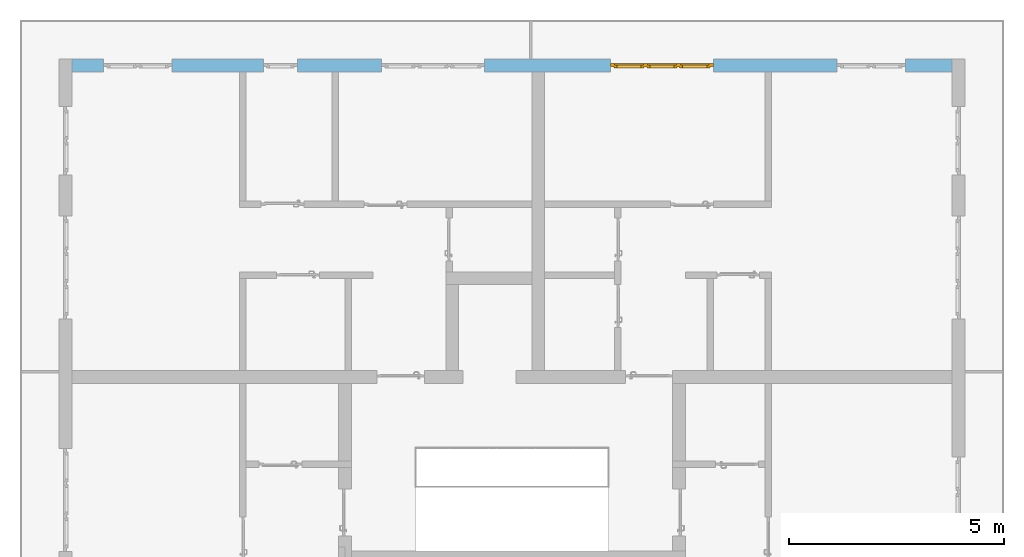
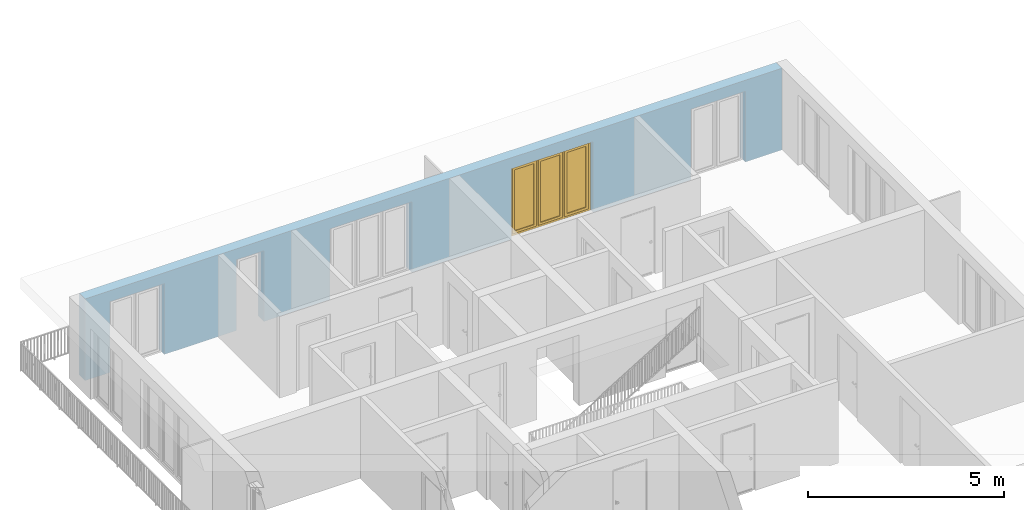
# One storey, part 28 of 54: 1 window, 5 openings, plus 1 element that does not belong to this part.
"""IFC4 building model written with IfcOpenShell, lengths in metres."""

import ifcopenshell
import ifcopenshell.guid

model = None  # the IFC model being written
_history = None  # IfcOwnerHistory: only IFC2X3 demands one
_inside = {}  # id of a spatial element -> (the spatial element, [elements in it])
_under = {}  # id of a project, library or spatial element -> (it, [spatial elements below it])
_declared = {}  # id of a project -> (the project, [libraries it declares])
_typed = {}  # id of a type object -> (the type object, [elements of that type])
_made_of = {}  # id of a material, layer set ... -> (it, [elements and type objects made of it])


def new_model(schema):
    """Start an empty IFC model of exactly this schema.

    Asked for "IFC4X3", IfcOpenShell would pick the latest addendum, in which some entities
    have other attributes; the version numbers below select the first issue.
    IFC2X3 requires an IfcOwnerHistory on every rooted entity: one is made here for all.
    """
    global model, _history
    if schema == "IFC4X3":
        model = ifcopenshell.file(schema_version=(4, 3, 0, 0))
    else:
        model = ifcopenshell.file(schema=schema)
    _inside.clear()
    _under.clear()
    _declared.clear()
    _typed.clear()
    _made_of.clear()
    _history = None
    if model.schema == "IFC2X3":
        org = make("IfcOrganization", Name="unknown")
        user = make(
            "IfcPersonAndOrganization",
            ThePerson=make("IfcPerson", FamilyName="unknown"),
            TheOrganization=org,
        )
        app = make(
            "IfcApplication",
            ApplicationDeveloper=org,
            Version="unknown",
            ApplicationFullName="unknown",
            ApplicationIdentifier="unknown",
        )
        _history = make(
            "IfcOwnerHistory",
            OwningUser=user,
            OwningApplication=app,
            ChangeAction="ADDED",
            CreationDate=0,
        )
    return model


def make(cls, **values):
    """One entity of the class cls with the attributes given. An attribute that is None is left unset."""
    return model.create_entity(
        cls, **{name: value for name, value in values.items() if value is not None}
    )


def entity(cls, *values):
    """Any entity or typed value of the class cls, its attributes in the order of the schema. None: left unset."""
    e = model.create_entity(cls)
    for i, value in enumerate(values):
        if value is not None:
            e[i] = value
    return e


def rooted(cls, **values):
    """An entity with a GlobalId (a new one), such as an element, a storey or a relation."""
    return make(cls, GlobalId=ifcopenshell.guid.new(), OwnerHistory=_history, **values)


def si_unit(unit_type, name, prefix=None):
    """IfcSIUnit, for example si_unit("LENGTHUNIT", "METRE", prefix="MILLI")."""
    return make("IfcSIUnit", UnitType=unit_type, Prefix=prefix, Name=name)


def converted_unit(unit_type, name, factor, base, dimensions=None, offset=None):
    """IfcConversionBasedUnit, such as the inch: factor (a typed value) times the base unit."""
    return make(
        "IfcConversionBasedUnit"
        if offset is None
        else "IfcConversionBasedUnitWithOffset",
        ConversionOffset=offset,
        Dimensions=None
        if dimensions is None
        else entity("IfcDimensionalExponents", *dimensions),
        UnitType=unit_type,
        Name=name,
        ConversionFactor=make(
            "IfcMeasureWithUnit", ValueComponent=factor, UnitComponent=base
        ),
    )


def derived_unit(unit_type, elements):
    """IfcDerivedUnit: a product of units, each with its exponent."""
    return make(
        "IfcDerivedUnit",
        Elements=[
            make("IfcDerivedUnitElement", Unit=unit, Exponent=power)
            for unit, power in elements
        ],
        UnitType=unit_type,
    )


def assignment(units):
    """IfcUnitAssignment: the units of a project."""
    return None if units is None else make("IfcUnitAssignment", Units=units)


def point(xyz):
    """IfcCartesianPoint."""
    return None if xyz is None else make("IfcCartesianPoint", Coordinates=xyz)


def direction(xyz):
    """IfcDirection."""
    return None if xyz is None else make("IfcDirection", DirectionRatios=xyz)


def frame(location, z_axis=None, x_axis=None):
    """IfcAxis2Placement3D, a coordinate frame: its origin and axes. An axis left out is left unset."""
    return make(
        "IfcAxis2Placement3D",
        Location=point(location),
        Axis=direction(z_axis),
        RefDirection=direction(x_axis),
    )


def origin_with_axes():
    """The frame at (0, 0, 0) with the z axis (0, 0, 1) and the x axis (1, 0, 0) written out."""
    return frame((0.0, 0.0, 0.0), z_axis=(0.0, 0.0, 1.0), x_axis=(1.0, 0.0, 0.0))


def place(relative_to, where):
    """IfcLocalPlacement: puts the frame where relative to a parent placement (None: the world)."""
    return make(
        "IfcLocalPlacement", PlacementRelTo=relative_to, RelativePlacement=where
    )


def context(
    kind, dimensions, precision=None, world=None, true_north=None, identifier=None
):
    """IfcGeometricRepresentationContext, for example the 3D "Model" context."""
    return make(
        "IfcGeometricRepresentationContext",
        ContextIdentifier=identifier,
        ContextType=kind,
        CoordinateSpaceDimension=dimensions,
        Precision=precision,
        WorldCoordinateSystem=world,
        TrueNorth=true_north,
    )


def subcontext(parent, identifier, kind, view, scale=None):
    """IfcGeometricRepresentationSubContext, for example "Body" below "Model"."""
    return make(
        "IfcGeometricRepresentationSubContext",
        ContextIdentifier=identifier,
        ContextType=kind,
        ParentContext=parent,
        TargetScale=scale,
        TargetView=view,
    )


def project(units=None, contexts=None):
    """IfcProject with its units and contexts."""
    return rooted(
        "IfcProject",
        Name="project",
        RepresentationContexts=contexts,
        UnitsInContext=assignment(units),
    )


def spatial(cls, under=None, at=None, **own):
    """A site, building, storey or space (cls), placed at a placement, below another one or the project."""
    s = rooted(cls, ObjectPlacement=at, **own)
    if under is not None:
        _under.setdefault(under.id(), (under, []))[1].append(s)
    return s


def point_list(points):
    """IfcCartesianPointList2D or 3D."""
    cls = (
        "IfcCartesianPointList2D" if len(points[0]) == 2 else "IfcCartesianPointList3D"
    )
    return make(cls, CoordList=points)


def polygons(points, faces, closed=None, point_numbers=None):
    """IfcPolygonalFaceSet: a face is its outer loop, then its inner loops; points numbered from 1."""
    made = []
    for loops in faces:
        if len(loops) == 1:
            made.append(make("IfcIndexedPolygonalFace", CoordIndex=loops[0]))
        else:
            made.append(
                make(
                    "IfcIndexedPolygonalFaceWithVoids",
                    CoordIndex=loops[0],
                    InnerCoordIndices=loops[1:],
                )
            )
    return make(
        "IfcPolygonalFaceSet",
        Coordinates=point_list(points),
        Closed=closed,
        Faces=made,
        PnIndex=point_numbers,
    )


def shape(context_of_items, identifier, shape_type, items):
    """IfcShapeRepresentation: the items that make up one representation, for example the "Body"."""
    return make(
        "IfcShapeRepresentation",
        ContextOfItems=context_of_items,
        RepresentationIdentifier=identifier,
        RepresentationType=shape_type,
        Items=items,
    )


def source(mapping_origin, context_of_items, identifier, shape_type, items):
    """IfcRepresentationMap: a shape defined once, which mapped items show again and again."""
    return make(
        "IfcRepresentationMap",
        MappingOrigin=mapping_origin,
        MappedRepresentation=shape(context_of_items, identifier, shape_type, items),
    )


def transform(
    local_origin,
    x_axis=None,
    y_axis=None,
    z_axis=None,
    scale=None,
    scale2=None,
    scale3=None,
    uniform=True,
):
    """IfcCartesianTransformationOperator3D, or its non-uniform kind. x_axis, y_axis, z_axis: its Axis1, 2, 3."""
    if uniform:
        return make(
            "IfcCartesianTransformationOperator3D",
            Axis1=direction(x_axis),
            Axis2=direction(y_axis),
            LocalOrigin=point(local_origin),
            Scale=scale,
            Axis3=direction(z_axis),
        )
    return make(
        "IfcCartesianTransformationOperator3DnonUniform",
        Axis1=direction(x_axis),
        Axis2=direction(y_axis),
        LocalOrigin=point(local_origin),
        Scale=scale,
        Axis3=direction(z_axis),
        Scale2=scale2,
        Scale3=scale3,
    )


def mapped(mapping_source, mapping_target):
    """IfcMappedItem: shows the shape of a source again, moved by a transform."""
    return make(
        "IfcMappedItem", MappingSource=mapping_source, MappingTarget=mapping_target
    )


def material(Name=None, Category=None):
    """IfcMaterial."""
    return make("IfcMaterial", Name=Name, Category=Category)


def made_of(thing, what):
    """Note that an element or type object is made of a material, layer set ...; save() writes the relation."""
    if what is not None:
        _made_of.setdefault(what.id(), (what, []))[1].append(thing)
    return thing


def type_object(cls, material=None, **own):
    """A type object (cls), such as IfcWallType, which elements share."""
    return made_of(rooted(cls, **own), material)


def element(
    cls,
    number,
    at=None,
    inside=None,
    cuts=None,
    type_object=None,
    material=None,
    context=None,
    identifier="Body",
    shape_type=None,
    held_by="IfcProductDefinitionShape",
    body=None,
    shapes=None,
    **own,
):
    """One element of the class cls, such as IfcWall. Its Tag is "e" and its number.

    at: its placement. inside: the storey or other place that contains it. cuts: it is an
    opening in that element (IfcRelVoidsElement). A single representation is given by context,
    identifier, shape_type and body (its items); several are given by shapes. held_by: the class
    of the entity that holds the representations. save() writes the other relations.
    """
    e = rooted(cls, Tag="e%d" % number, ObjectPlacement=at, **own)
    if body is not None:
        shapes = [shape(context, identifier, shape_type, body)]
    if shapes is not None:
        e.Representation = make(held_by, Representations=shapes)
    if inside is not None:
        _inside.setdefault(inside.id(), (inside, []))[1].append(e)
    if cuts is not None:
        rooted(
            "IfcRelVoidsElement", RelatingBuildingElement=cuts, RelatedOpeningElement=e
        )
    if type_object is not None:
        _typed.setdefault(type_object.id(), (type_object, []))[1].append(e)
    return made_of(e, material)


def fill(opening, filler):
    """IfcRelFillsElement: the door or window that sits in an opening."""
    return rooted(
        "IfcRelFillsElement",
        RelatingOpeningElement=opening,
        RelatedBuildingElement=filler,
    )


def aggregate(whole, parts):
    """IfcRelAggregates: a whole, such as a stair, and the parts it consists of."""
    return rooted("IfcRelAggregates", RelatingObject=whole, RelatedObjects=parts)


def save(model, path):
    """Write the relations noted so far, then the file.

    IfcRelAggregates (storeys below a building ...), IfcRelContainedInSpatialStructure (elements
    in a storey), IfcRelDefinesByType, IfcRelAssociatesMaterial and IfcRelDeclares: one each for
    every whole, place, type object, material and project.
    """
    for whole, parts in _under.values():
        aggregate(whole, parts)
    for where, things in _inside.values():
        rooted(
            "IfcRelContainedInSpatialStructure",
            RelatedElements=things,
            RelatingStructure=where,
        )
    for kind, things in _typed.values():
        rooted("IfcRelDefinesByType", RelatedObjects=things, RelatingType=kind)
    for what, things in _made_of.values():
        rooted("IfcRelAssociatesMaterial", RelatedObjects=things, RelatingMaterial=what)
    for by, libraries in _declared.values():
        rooted("IfcRelDeclares", RelatingContext=by, RelatedDefinitions=libraries)
    model.write(path)


model = new_model("IFC4")

# Units and contexts
model_context = context("Model", 3, precision=1e-05, world=origin_with_axes(), true_north=direction((0.0, 1.0)))
body_context = subcontext(model_context, "Body", "Model", "MODEL_VIEW")
ifc_project = project(units=[si_unit("LENGTHUNIT", "METRE"), si_unit("AREAUNIT", "SQUARE_METRE"), si_unit("VOLUMEUNIT", "CUBIC_METRE"), converted_unit("PLANEANGLEUNIT", "DEGREE", entity("IfcPlaneAngleMeasure", 0.0174532925199), si_unit("PLANEANGLEUNIT", "RADIAN"), dimensions=[0, 0, 0, 0, 0, 0, 0]), converted_unit("TIMEUNIT", "Year", entity("IfcTimeMeasure", 31556926.0), si_unit("TIMEUNIT", "SECOND"), dimensions=[0, 0, 1, 0, 0, 0, 0]), si_unit("MASSUNIT", "GRAM", prefix="KILO"), si_unit("THERMODYNAMICTEMPERATUREUNIT", "DEGREE_CELSIUS"), si_unit("LUMINOUSINTENSITYUNIT", "LUMEN"), si_unit("ENERGYUNIT", "JOULE", prefix="MEGA"), derived_unit("THERMALCONDUCTANCEUNIT", [(si_unit("POWERUNIT", "WATT"), 1), (si_unit("LENGTHUNIT", "METRE"), -1), (si_unit("THERMODYNAMICTEMPERATUREUNIT", "KELVIN"), -1)]), derived_unit("SPECIFICHEATCAPACITYUNIT", [(si_unit("ENERGYUNIT", "JOULE"), 1), (si_unit("MASSUNIT", "GRAM", prefix="KILO"), -1), (si_unit("THERMODYNAMICTEMPERATUREUNIT", "KELVIN"), -1)]), derived_unit("MASSDENSITYUNIT", [(si_unit("MASSUNIT", "GRAM", prefix="KILO"), 1), (si_unit("VOLUMEUNIT", "CUBIC_METRE"), -1)])], contexts=[model_context])

# Site, building, storey
site_placement = place(None, origin_with_axes())
site = spatial("IfcSite", under=ifc_project, at=site_placement, CompositionType="ELEMENT")
building_placement = place(site_placement, origin_with_axes())
building = spatial("IfcBuilding", under=site, at=building_placement, CompositionType="ELEMENT")
storey_placement = place(building_placement, frame((0.0, 0.0, 6.29), z_axis=(0.0, 0.0, 1.0), x_axis=(1.0, 0.0, 0.0)))
storey = spatial("IfcBuildingStorey", under=building, at=storey_placement, Name="2. Geschoss", CompositionType="ELEMENT", Elevation=6.29)

# Wall, openings, window
ifc_material = material()
wall_type = type_object("IfcWallType", Name="300", PredefinedType="NOTDEFINED")
wall_placement = place(storey_placement, frame((-11.7421993804, 8.92118776896, 0.0), z_axis=(0.0, 0.0, 1.0), x_axis=(1.0, 0.0, 0.0)))
wall = element("IfcWall", 1, at=wall_placement, inside=storey, type_object=wall_type, material=ifc_material, Name="Wand-001", PredefinedType="NOTDEFINED", context=body_context, shape_type="Tessellation", body=[
    polygons([(15.23, -0.1, 0.0), (15.23, -0.3, 0.0), (15.23, -0.3, 2.2), (15.23, 0.0, 2.2), (15.23, 0.0, 0.0), (18.102139809, 0.0, 0.0), (18.102139809, -0.3, 0.0), (18.102139809, -0.3, 2.2), (19.702139809, -0.3, 2.2), (19.702139809, -0.3, 0.0), (20.78, -0.3, 0.0), (20.78, -0.3, 2.54), (0.3, -0.3, 2.54), (0.3, -0.3, 0.0), (1.0288518641, -0.3, 0.0), (1.0288518641, -0.3, 2.2), (2.6288518641, -0.3, 2.2), (2.6288518641, -0.3, 0.0), (4.75, -0.3, 0.0), (4.75, -0.3, 2.2), (5.55, -0.3, 2.2), (5.55, -0.3, 0.0), (7.50089858046, -0.3, 0.0), (7.50089858046, -0.3, 2.2), (9.90089858046, -0.3, 2.2), (9.90089858046, -0.3, 0.0), (12.83, -0.3, 0.0), (12.83, -0.3, 2.2), (12.83, 0.0, 2.2), (12.83, 0.0, 0.0), (9.90089858046, 0.0, 0.0), (9.90089858046, 0.0, 2.2), (7.50089858046, 0.0, 2.2), (7.50089858046, 0.0, 0.0), (5.55, 0.0, 0.0), (5.55, 0.0, 2.2), (4.75, 0.0, 2.2), (4.75, 0.0, 0.0), (2.6288518641, 0.0, 0.0), (2.6288518641, 0.0, 2.2), (1.0288518641, 0.0, 2.2), (1.0288518641, 0.0, 0.0), (0.3, 0.0, 0.0), (0.3, 0.0, 2.54), (20.78, 0.0, 2.54), (20.78, 0.0, 0.0), (19.702139809, 0.0, 0.0), (19.702139809, 0.0, 2.2), (18.102139809, 0.0, 2.2), (12.83, -0.1, 0.0)], [[[1, 2, 3, 4, 5]], [[2, 1, 5, 6, 7]], [[3, 2, 7, 8, 9, 10, 11, 12, 13, 14, 15, 16, 17, 18, 19, 20, 21, 22, 23, 24, 25, 26, 27, 28]], [[4, 3, 28, 29]], [[6, 5, 4, 29, 30, 31, 32, 33, 34, 35, 36, 37, 38, 39, 40, 41, 42, 43, 44, 45, 46, 47, 48, 49]], [[6, 49, 8, 7]], [[8, 49, 48, 9]], [[48, 47, 10, 9]], [[46, 11, 10, 47]], [[12, 11, 46, 45]], [[45, 44, 13, 12]], [[44, 43, 14, 13]], [[15, 14, 43, 42]], [[16, 15, 42, 41]], [[40, 17, 16, 41]], [[18, 17, 40, 39]], [[19, 18, 39, 38]], [[20, 19, 38, 37]], [[36, 21, 20, 37]], [[22, 21, 36, 35]], [[22, 35, 34, 23]], [[34, 33, 24, 23]], [[24, 33, 32, 25]], [[32, 31, 26, 25]], [[50, 27, 26, 31, 30]], [[28, 27, 50, 30, 29]]], closed=True),
])
opening_1_placement = place(wall_placement, frame((1.8288518641, 0.0, 0.0), z_axis=(0.0, 0.0, 1.0), x_axis=(1.0, 0.0, 0.0)))
element("IfcOpeningElement", 2, at=opening_1_placement, cuts=wall, Name="Fenster-001", context=body_context, identifier="Reference", shape_type="Tessellation", body=[
    polygons([(-0.8, -0.1, 0.0), (-0.8, -0.1, 2.2), (-0.8, 0.000999999999998, 2.2), (-0.8, 0.000999999999998, 0.0), (-0.8, -0.301, 0.0), (-0.8, -0.301, 2.2), (0.8, -0.1, 2.2), (0.8, 0.000999999999999, 2.2), (0.8, -0.301, 2.2), (0.8, 0.000999999999999, 0.0), (0.8, -0.1, 0.0), (0.8, -0.301, 0.0)], [[[1, 2, 3, 4]], [[2, 1, 5, 6]], [[7, 8, 3, 2, 6, 9]], [[8, 10, 4, 3]], [[1, 4, 10, 11, 12, 5]], [[6, 5, 12, 9]], [[7, 11, 10, 8]], [[11, 7, 9, 12]]], closed=True),
])
opening_2_placement = place(wall_placement, frame((8.70089858046, 0.0, 0.0), z_axis=(0.0, 0.0, 1.0), x_axis=(1.0, 0.0, 0.0)))
element("IfcOpeningElement", 3, at=opening_2_placement, cuts=wall, Name="Fenster-002", context=body_context, identifier="Reference", shape_type="Tessellation", body=[
    polygons([(-1.2, -0.1, 0.0), (-1.2, -0.1, 2.2), (-1.2, 0.000999999999999, 2.2), (-1.2, 0.000999999999999, 0.0), (-1.2, -0.301, 0.0), (-1.2, -0.301, 2.2), (1.2, -0.1, 2.2), (1.2, 0.001, 2.2), (1.2, -0.301, 2.2), (1.2, 0.001, 0.0), (1.2, -0.1, 0.0), (1.2, -0.301, 0.0)], [[[1, 2, 3, 4]], [[2, 1, 5, 6]], [[7, 8, 3, 2, 6, 9]], [[8, 10, 4, 3]], [[1, 4, 10, 11, 12, 5]], [[6, 5, 12, 9]], [[7, 11, 10, 8]], [[11, 7, 9, 12]]], closed=True),
])
opening_3_placement = place(wall_placement, frame((5.15, 0.0, 0.0), z_axis=(0.0, 0.0, 1.0), x_axis=(1.0, 0.0, 0.0)))
element("IfcOpeningElement", 4, at=opening_3_placement, cuts=wall, Name="Fenster-003", context=body_context, identifier="Reference", shape_type="Tessellation", body=[
    polygons([(-0.4, -0.1, 0.0), (-0.4, -0.1, 2.2), (-0.4, 0.001, 2.2), (-0.4, 0.001, 0.0), (-0.4, -0.301, 0.0), (-0.4, -0.301, 2.2), (0.4, -0.1, 2.2), (0.4, 0.001, 2.2), (0.4, -0.301, 2.2), (0.4, 0.001, 0.0), (0.4, -0.1, 0.0), (0.4, -0.301, 0.0)], [[[1, 2, 3, 4]], [[2, 1, 5, 6]], [[7, 8, 3, 2, 6, 9]], [[8, 10, 4, 3]], [[1, 4, 10, 11, 12, 5]], [[6, 5, 12, 9]], [[7, 11, 10, 8]], [[11, 7, 9, 12]]], closed=True),
])
opening_4_placement = place(wall_placement, frame((18.902139809, 0.0, 0.0), z_axis=(0.0, 0.0, 1.0), x_axis=(1.0, 0.0, 0.0)))
element("IfcOpeningElement", 5, at=opening_4_placement, cuts=wall, Name="Fenster-001", context=body_context, identifier="Reference", shape_type="Tessellation", body=[
    polygons([(-0.8, -0.1, 0.0), (-0.8, -0.1, 2.2), (-0.8, 0.001, 2.2), (-0.8, 0.001, 0.0), (-0.8, -0.301, 0.0), (-0.8, -0.301, 2.2), (0.8, -0.1, 2.2), (0.8, 0.001, 2.2), (0.8, -0.301, 2.2), (0.8, 0.001, 0.0), (0.8, -0.1, 0.0), (0.8, -0.301, 0.0)], [[[1, 2, 3, 4]], [[2, 1, 5, 6]], [[7, 8, 3, 2, 6, 9]], [[8, 10, 4, 3]], [[1, 4, 10, 11, 12, 5]], [[6, 5, 12, 9]], [[7, 11, 10, 8]], [[11, 7, 9, 12]]], closed=True),
])
opening_5_placement = place(wall_placement, frame((14.03, 0.0, 0.0), z_axis=(0.0, 0.0, 1.0), x_axis=(1.0, 0.0, 0.0)))
opening_5 = element("IfcOpeningElement", 6, at=opening_5_placement, cuts=wall, Name="Fenster-002", context=body_context, identifier="Reference", shape_type="Tessellation", body=[
    polygons([(-1.2, -0.1, 0.0), (-1.2, -0.1, 2.2), (-1.2, 0.001, 2.2), (-1.2, 0.001, 0.0), (-1.2, -0.301, 0.0), (-1.2, -0.301, 2.2), (1.2, -0.1, 2.2), (1.2, 0.001, 2.2), (1.2, -0.301, 2.2), (1.2, 0.001, 0.0), (1.2, -0.1, 0.0), (1.2, -0.301, 0.0)], [[[1, 2, 3, 4]], [[2, 1, 5, 6]], [[7, 8, 3, 2, 6, 9]], [[8, 10, 4, 3]], [[1, 4, 10, 11, 12, 5]], [[6, 5, 12, 9]], [[7, 11, 10, 8]], [[11, 7, 9, 12]]], closed=True),
])
window_type = type_object("IfcWindowType", Name="3-1+1+1 26", PartitioningType="TRIPLE_PANEL_VERTICAL", PredefinedType="WINDOW")
shared_shape = source(origin_with_axes(), body_context, "Body", "Tessellation", [
    polygons([(-1.2, -0.07, 0.0), (-1.2, 0.0, 0.0), (-1.1, 0.0, 0.1), (-1.1, -0.07, 0.1), (-1.2, -0.07, 2.2), (-1.2, 0.0, 2.2), (-1.1, 0.0, 2.1), (-1.1, -0.07, 2.1)], [[[1, 2, 3, 4]], [[5, 6, 2, 1]], [[2, 6, 7, 3]], [[4, 3, 7, 8]], [[1, 4, 8, 5]], [[8, 7, 6, 5]]], closed=True),
    polygons([(1.2, -0.07, 0.0), (1.2, 0.0, 0.0), (1.2, 0.0, 2.2), (1.2, -0.07, 2.2), (1.1, -0.07, 0.1), (1.1, 0.0, 0.1), (1.1, 0.0, 2.1), (1.1, -0.07, 2.1)], [[[1, 2, 3, 4]], [[5, 6, 2, 1]], [[2, 6, 7, 3]], [[4, 3, 7, 8]], [[1, 4, 8, 5]], [[8, 7, 6, 5]]], closed=True),
    polygons([(-1.2, -0.07, 0.0), (-1.2, 0.0, 0.0), (1.2, 0.0, 0.0), (1.2, -0.07, 0.0), (-1.1, -0.07, 0.1), (-1.1, 0.0, 0.1), (-0.433333333333, 0.0, 0.1), (-0.333333333333, 0.0, 0.1), (0.333333333333, 0.0, 0.1), (0.433333333333, 0.0, 0.1), (1.1, 0.0, 0.1), (1.1, -0.07, 0.1), (0.433333333333, -0.07, 0.1), (0.333333333333, -0.07, 0.1), (-0.333333333333, -0.07, 0.1), (-0.433333333333, -0.07, 0.1)], [[[1, 2, 3, 4]], [[5, 6, 2, 1]], [[2, 6, 7, 8, 9, 10, 11, 3]], [[4, 3, 11, 12]], [[1, 4, 12, 13, 14, 15, 16, 5]], [[16, 7, 6, 5]], [[15, 8, 7, 16]], [[14, 9, 8, 15]], [[13, 10, 9, 14]], [[12, 11, 10, 13]]], closed=True),
    polygons([(-1.2, -0.07, 2.2), (-1.2, 0.0, 2.2), (-1.1, 0.0, 2.1), (-1.1, -0.07, 2.1), (1.2, -0.07, 2.2), (1.2, 0.0, 2.2), (1.1, 0.0, 2.1), (0.433333333333, 0.0, 2.1), (0.333333333333, 0.0, 2.1), (-0.333333333333, 0.0, 2.1), (-0.433333333333, 0.0, 2.1), (-0.433333333333, -0.07, 2.1), (-0.333333333333, -0.07, 2.1), (0.333333333333, -0.07, 2.1), (0.433333333333, -0.07, 2.1), (1.1, -0.07, 2.1)], [[[1, 2, 3, 4]], [[5, 6, 2, 1]], [[2, 6, 7, 8, 9, 10, 11, 3]], [[4, 3, 11, 12]], [[1, 4, 12, 13, 14, 15, 16, 5]], [[16, 7, 6, 5]], [[15, 8, 7, 16]], [[14, 9, 8, 15]], [[13, 10, 9, 14]], [[12, 11, 10, 13]]], closed=True),
    polygons([(0.333333333333, -0.07, 0.1), (0.333333333333, 0.0, 0.1), (0.433333333333, 0.0, 0.1), (0.433333333333, -0.07, 0.1), (0.333333333333, -0.07, 2.1), (0.333333333333, 0.0, 2.1), (0.433333333333, 0.0, 2.1), (0.433333333333, -0.07, 2.1)], [[[1, 2, 3, 4]], [[5, 6, 2, 1]], [[2, 6, 7, 3]], [[4, 3, 7, 8]], [[1, 4, 8, 5]], [[8, 7, 6, 5]]], closed=True),
    polygons([(-0.433333333333, -0.07, 0.1), (-0.433333333333, 0.0, 0.1), (-0.333333333333, 0.0, 0.1), (-0.333333333333, -0.07, 0.1), (-0.433333333333, -0.07, 2.1), (-0.433333333333, 0.0, 2.1), (-0.333333333333, 0.0, 2.1), (-0.333333333333, -0.07, 2.1)], [[[1, 2, 3, 4]], [[5, 6, 2, 1]], [[2, 6, 7, 3]], [[4, 3, 7, 8]], [[1, 4, 8, 5]], [[8, 7, 6, 5]]], closed=True),
    polygons([(-1.12, 0.0, 0.08), (-1.12, 0.03, 0.08), (-1.05, 0.03, 0.15), (-1.05, 0.0, 0.15), (-1.12, 0.0, 2.12), (-1.12, 0.03, 2.12), (-1.05, 0.03, 2.05), (-1.05, 0.0, 2.05)], [[[1, 2, 3, 4]], [[5, 6, 2, 1]], [[2, 6, 7, 3]], [[4, 3, 7, 8]], [[1, 4, 8, 5]], [[8, 7, 6, 5]]], closed=True),
    polygons([(-0.413333333333, 0.0, 0.08), (-0.483333333333, 0.0, 0.15), (-0.483333333333, 0.03, 0.15), (-0.413333333333, 0.03, 0.08), (-0.413333333333, 0.0, 2.12), (-0.483333333333, 0.0, 2.05), (-0.483333333333, 0.03, 2.05), (-0.413333333333, 0.03, 2.12)], [[[1, 2, 3, 4]], [[1, 5, 6, 2]], [[2, 6, 7, 3]], [[4, 3, 7, 8]], [[5, 1, 4, 8]], [[6, 5, 8, 7]]], closed=True),
    polygons([(-1.12, 0.0, 0.08), (-1.12, 0.03, 0.08), (-0.413333333333, 0.03, 0.08), (-0.413333333333, 0.0, 0.08), (-1.05, 0.0, 0.15), (-1.05, 0.03, 0.15), (-0.483333333333, 0.03, 0.15), (-0.483333333333, 0.0, 0.15)], [[[1, 2, 3, 4]], [[5, 6, 2, 1]], [[2, 6, 7, 3]], [[4, 3, 7, 8]], [[1, 4, 8, 5]], [[8, 7, 6, 5]]], closed=True),
    polygons([(-1.12, 0.0, 2.12), (-0.413333333333, 0.0, 2.12), (-0.413333333333, 0.03, 2.12), (-1.12, 0.03, 2.12), (-1.05, 0.0, 2.05), (-0.483333333333, 0.0, 2.05), (-0.483333333333, 0.03, 2.05), (-1.05, 0.03, 2.05)], [[[1, 2, 3, 4]], [[1, 5, 6, 2]], [[2, 6, 7, 3]], [[4, 3, 7, 8]], [[5, 1, 4, 8]], [[6, 5, 8, 7]]], closed=True),
    polygons([(-1.1, -0.03, 0.1), (-1.1, 0.0, 0.1), (-1.05, 0.0, 0.15), (-1.05, -0.03, 0.15), (-1.1, -0.03, 2.1), (-1.1, 0.0, 2.1), (-1.05, 0.0, 2.05), (-1.05, -0.03, 2.05)], [[[1, 2, 3, 4]], [[5, 6, 2, 1]], [[2, 6, 7, 3]], [[4, 3, 7, 8]], [[1, 4, 8, 5]], [[8, 7, 6, 5]]], closed=True),
    polygons([(-0.433333333333, -0.03, 0.1), (-0.483333333333, -0.03, 0.15), (-0.483333333333, 0.0, 0.15), (-0.433333333333, 0.0, 0.1), (-0.433333333333, -0.03, 2.1), (-0.483333333333, -0.03, 2.05), (-0.483333333333, 0.0, 2.05), (-0.433333333333, 0.0, 2.1)], [[[1, 2, 3, 4]], [[1, 5, 6, 2]], [[2, 6, 7, 3]], [[4, 3, 7, 8]], [[5, 1, 4, 8]], [[6, 5, 8, 7]]], closed=True),
    polygons([(-1.1, -0.03, 0.1), (-1.1, 0.0, 0.1), (-0.433333333333, 0.0, 0.1), (-0.433333333333, -0.03, 0.1), (-1.05, -0.03, 0.15), (-1.05, 0.0, 0.15), (-0.483333333333, 0.0, 0.15), (-0.483333333333, -0.03, 0.15)], [[[1, 2, 3, 4]], [[5, 6, 2, 1]], [[2, 6, 7, 3]], [[4, 3, 7, 8]], [[1, 4, 8, 5]], [[8, 7, 6, 5]]], closed=True),
    polygons([(-1.1, -0.03, 2.1), (-0.433333333333, -0.03, 2.1), (-0.433333333333, 0.0, 2.1), (-1.1, 0.0, 2.1), (-1.05, -0.03, 2.05), (-0.483333333333, -0.03, 2.05), (-0.483333333333, 0.0, 2.05), (-1.05, 0.0, 2.05)], [[[1, 2, 3, 4]], [[1, 5, 6, 2]], [[2, 6, 7, 3]], [[4, 3, 7, 8]], [[5, 1, 4, 8]], [[6, 5, 8, 7]]], closed=True),
    polygons([(-1.05, -0.005, 0.15), (-1.05, 0.005, 0.15), (-0.483333333333, 0.005, 0.15), (-0.483333333333, -0.005, 0.15), (-1.05, -0.005, 2.05), (-1.05, 0.005, 2.05), (-0.483333333333, 0.005, 2.05), (-0.483333333333, -0.005, 2.05)], [[[1, 2, 3, 4]], [[5, 6, 2, 1]], [[2, 6, 7, 3]], [[4, 3, 7, 8]], [[1, 4, 8, 5]], [[8, 7, 6, 5]]], closed=True),
    polygons([(-0.353333333333, 0.0, 0.08), (-0.353333333333, 0.03, 0.08), (-0.283333333333, 0.03, 0.15), (-0.283333333333, 0.0, 0.15), (-0.353333333333, 0.0, 2.12), (-0.353333333333, 0.03, 2.12), (-0.283333333333, 0.03, 2.05), (-0.283333333333, 0.0, 2.05)], [[[1, 2, 3, 4]], [[5, 6, 2, 1]], [[2, 6, 7, 3]], [[4, 3, 7, 8]], [[1, 4, 8, 5]], [[8, 7, 6, 5]]], closed=True),
    polygons([(0.353333333333, 0.0, 0.08), (0.283333333333, 0.0, 0.15), (0.283333333333, 0.03, 0.15), (0.353333333333, 0.03, 0.08), (0.353333333333, 0.0, 2.12), (0.283333333333, 0.0, 2.05), (0.283333333333, 0.03, 2.05), (0.353333333333, 0.03, 2.12)], [[[1, 2, 3, 4]], [[1, 5, 6, 2]], [[2, 6, 7, 3]], [[4, 3, 7, 8]], [[5, 1, 4, 8]], [[6, 5, 8, 7]]], closed=True),
    polygons([(-0.353333333333, 0.0, 0.08), (-0.353333333333, 0.03, 0.08), (0.353333333333, 0.03, 0.08), (0.353333333333, 0.0, 0.08), (-0.283333333333, 0.0, 0.15), (-0.283333333333, 0.03, 0.15), (0.283333333333, 0.03, 0.15), (0.283333333333, 0.0, 0.15)], [[[1, 2, 3, 4]], [[5, 6, 2, 1]], [[2, 6, 7, 3]], [[4, 3, 7, 8]], [[1, 4, 8, 5]], [[8, 7, 6, 5]]], closed=True),
    polygons([(-0.353333333333, 0.0, 2.12), (0.353333333333, 0.0, 2.12), (0.353333333333, 0.03, 2.12), (-0.353333333333, 0.03, 2.12), (-0.283333333333, 0.0, 2.05), (0.283333333333, 0.0, 2.05), (0.283333333333, 0.03, 2.05), (-0.283333333333, 0.03, 2.05)], [[[1, 2, 3, 4]], [[1, 5, 6, 2]], [[2, 6, 7, 3]], [[4, 3, 7, 8]], [[5, 1, 4, 8]], [[6, 5, 8, 7]]], closed=True),
    polygons([(-0.333333333333, -0.03, 0.1), (-0.333333333333, 0.0, 0.1), (-0.283333333333, 0.0, 0.15), (-0.283333333333, -0.03, 0.15), (-0.333333333333, -0.03, 2.1), (-0.333333333333, 0.0, 2.1), (-0.283333333333, 0.0, 2.05), (-0.283333333333, -0.03, 2.05)], [[[1, 2, 3, 4]], [[5, 6, 2, 1]], [[2, 6, 7, 3]], [[4, 3, 7, 8]], [[1, 4, 8, 5]], [[8, 7, 6, 5]]], closed=True),
    polygons([(0.333333333333, -0.03, 0.1), (0.283333333333, -0.03, 0.15), (0.283333333333, 0.0, 0.15), (0.333333333333, 0.0, 0.1), (0.333333333333, -0.03, 2.1), (0.283333333333, -0.03, 2.05), (0.283333333333, 0.0, 2.05), (0.333333333333, 0.0, 2.1)], [[[1, 2, 3, 4]], [[1, 5, 6, 2]], [[2, 6, 7, 3]], [[4, 3, 7, 8]], [[5, 1, 4, 8]], [[6, 5, 8, 7]]], closed=True),
    polygons([(-0.333333333333, -0.03, 0.1), (-0.333333333333, 0.0, 0.1), (0.333333333333, 0.0, 0.1), (0.333333333333, -0.03, 0.1), (-0.283333333333, -0.03, 0.15), (-0.283333333333, 0.0, 0.15), (0.283333333333, 0.0, 0.15), (0.283333333333, -0.03, 0.15)], [[[1, 2, 3, 4]], [[5, 6, 2, 1]], [[2, 6, 7, 3]], [[4, 3, 7, 8]], [[1, 4, 8, 5]], [[8, 7, 6, 5]]], closed=True),
    polygons([(-0.333333333333, -0.03, 2.1), (0.333333333333, -0.03, 2.1), (0.333333333333, 0.0, 2.1), (-0.333333333333, 0.0, 2.1), (-0.283333333333, -0.03, 2.05), (0.283333333333, -0.03, 2.05), (0.283333333333, 0.0, 2.05), (-0.283333333333, 0.0, 2.05)], [[[1, 2, 3, 4]], [[1, 5, 6, 2]], [[2, 6, 7, 3]], [[4, 3, 7, 8]], [[5, 1, 4, 8]], [[6, 5, 8, 7]]], closed=True),
    polygons([(-0.283333333333, -0.005, 0.15), (-0.283333333333, 0.005, 0.15), (0.283333333333, 0.005, 0.15), (0.283333333333, -0.005, 0.15), (-0.283333333333, -0.005, 2.05), (-0.283333333333, 0.005, 2.05), (0.283333333333, 0.005, 2.05), (0.283333333333, -0.005, 2.05)], [[[1, 2, 3, 4]], [[5, 6, 2, 1]], [[2, 6, 7, 3]], [[4, 3, 7, 8]], [[1, 4, 8, 5]], [[8, 7, 6, 5]]], closed=True),
    polygons([(0.413333333333, 0.0, 0.08), (0.413333333333, 0.03, 0.08), (0.483333333333, 0.03, 0.15), (0.483333333333, 0.0, 0.15), (0.413333333333, 0.0, 2.12), (0.413333333333, 0.03, 2.12), (0.483333333333, 0.03, 2.05), (0.483333333333, 0.0, 2.05)], [[[1, 2, 3, 4]], [[5, 6, 2, 1]], [[2, 6, 7, 3]], [[4, 3, 7, 8]], [[1, 4, 8, 5]], [[8, 7, 6, 5]]], closed=True),
    polygons([(1.12, 0.0, 0.08), (1.05, 0.0, 0.15), (1.05, 0.03, 0.15), (1.12, 0.03, 0.08), (1.12, 0.0, 2.12), (1.05, 0.0, 2.05), (1.05, 0.03, 2.05), (1.12, 0.03, 2.12)], [[[1, 2, 3, 4]], [[1, 5, 6, 2]], [[2, 6, 7, 3]], [[4, 3, 7, 8]], [[5, 1, 4, 8]], [[6, 5, 8, 7]]], closed=True),
    polygons([(0.413333333333, 0.0, 0.08), (0.413333333333, 0.03, 0.08), (1.12, 0.03, 0.08), (1.12, 0.0, 0.08), (0.483333333333, 0.0, 0.15), (0.483333333333, 0.03, 0.15), (1.05, 0.03, 0.15), (1.05, 0.0, 0.15)], [[[1, 2, 3, 4]], [[5, 6, 2, 1]], [[2, 6, 7, 3]], [[4, 3, 7, 8]], [[1, 4, 8, 5]], [[8, 7, 6, 5]]], closed=True),
    polygons([(0.413333333333, 0.0, 2.12), (1.12, 0.0, 2.12), (1.12, 0.03, 2.12), (0.413333333333, 0.03, 2.12), (0.483333333333, 0.0, 2.05), (1.05, 0.0, 2.05), (1.05, 0.03, 2.05), (0.483333333333, 0.03, 2.05)], [[[1, 2, 3, 4]], [[1, 5, 6, 2]], [[2, 6, 7, 3]], [[4, 3, 7, 8]], [[5, 1, 4, 8]], [[6, 5, 8, 7]]], closed=True),
    polygons([(0.433333333333, -0.03, 0.1), (0.433333333333, 0.0, 0.1), (0.483333333333, 0.0, 0.15), (0.483333333333, -0.03, 0.15), (0.433333333333, -0.03, 2.1), (0.433333333333, 0.0, 2.1), (0.483333333333, 0.0, 2.05), (0.483333333333, -0.03, 2.05)], [[[1, 2, 3, 4]], [[5, 6, 2, 1]], [[2, 6, 7, 3]], [[4, 3, 7, 8]], [[1, 4, 8, 5]], [[8, 7, 6, 5]]], closed=True),
    polygons([(1.1, -0.03, 0.1), (1.05, -0.03, 0.15), (1.05, 0.0, 0.15), (1.1, 0.0, 0.1), (1.1, -0.03, 2.1), (1.05, -0.03, 2.05), (1.05, 0.0, 2.05), (1.1, 0.0, 2.1)], [[[1, 2, 3, 4]], [[1, 5, 6, 2]], [[2, 6, 7, 3]], [[4, 3, 7, 8]], [[5, 1, 4, 8]], [[6, 5, 8, 7]]], closed=True),
    polygons([(0.433333333333, -0.03, 0.1), (0.433333333333, 0.0, 0.1), (1.1, 0.0, 0.1), (1.1, -0.03, 0.1), (0.483333333333, -0.03, 0.15), (0.483333333333, 0.0, 0.15), (1.05, 0.0, 0.15), (1.05, -0.03, 0.15)], [[[1, 2, 3, 4]], [[5, 6, 2, 1]], [[2, 6, 7, 3]], [[4, 3, 7, 8]], [[1, 4, 8, 5]], [[8, 7, 6, 5]]], closed=True),
    polygons([(0.433333333333, -0.03, 2.1), (1.1, -0.03, 2.1), (1.1, 0.0, 2.1), (0.433333333333, 0.0, 2.1), (0.483333333333, -0.03, 2.05), (1.05, -0.03, 2.05), (1.05, 0.0, 2.05), (0.483333333333, 0.0, 2.05)], [[[1, 2, 3, 4]], [[1, 5, 6, 2]], [[2, 6, 7, 3]], [[4, 3, 7, 8]], [[5, 1, 4, 8]], [[6, 5, 8, 7]]], closed=True),
    polygons([(0.483333333333, -0.005, 0.15), (0.483333333333, 0.005, 0.15), (1.05, 0.005, 0.15), (1.05, -0.005, 0.15), (0.483333333333, -0.005, 2.05), (0.483333333333, 0.005, 2.05), (1.05, 0.005, 2.05), (1.05, -0.005, 2.05)], [[[1, 2, 3, 4]], [[5, 6, 2, 1]], [[2, 6, 7, 3]], [[4, 3, 7, 8]], [[1, 4, 8, 5]], [[8, 7, 6, 5]]], closed=True),
])
window_placement = place(opening_5_placement, frame((1.2, 0.0, 0.0), z_axis=(0.0, 0.0, 1.0), x_axis=(-1.0, 0.0, 0.0)))
window = element("IfcWindow", 7, at=window_placement, inside=storey, type_object=window_type, Name="Fenster-002", OverallHeight=2.2, OverallWidth=2.4, PredefinedType="WINDOW", context=body_context, shape_type="MappedRepresentation", body=[
    mapped(shared_shape, transform((1.2, 0.17, 0.0))),
])
fill(opening_5, window)

save(model, "model.ifc")
